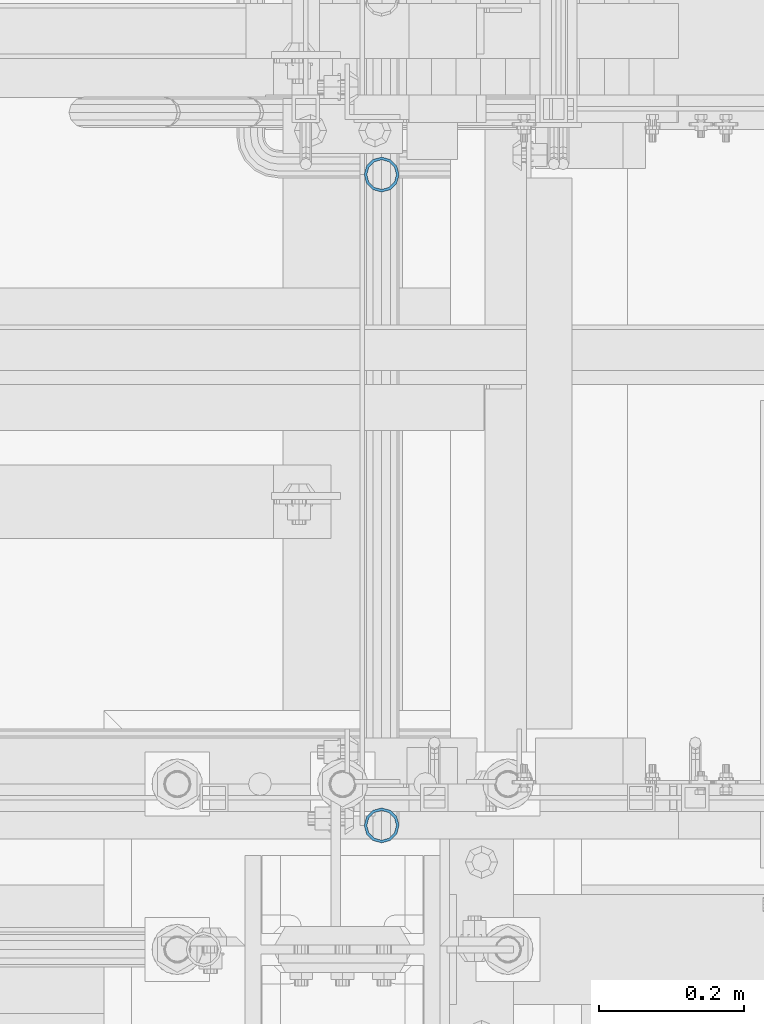
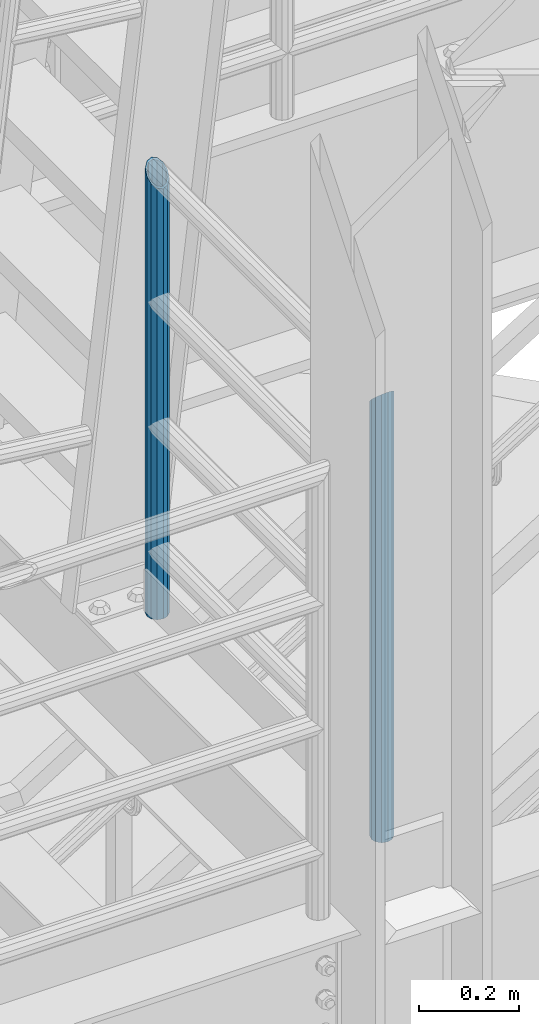
# One storey, part 572 of 1876: 2 columns, 1 element without a shape of its own.
"""IFC2X3 building model written with IfcOpenShell, lengths in millimetres."""

from ifc_helpers import new_model, si_unit, frame, origin_with_axes, place, context, subcontext, project, spatial, faceted_brep, material, type_object, element, aggregate, save


model = new_model("IFC2X3")

# Units and contexts
model_context = context("Model", 3, precision=1e-05, world=origin_with_axes())
body_context = subcontext(model_context, "Body", "Model", "MODEL_VIEW")
ifc_project = project(units=[si_unit("LENGTHUNIT", "METRE", prefix="MILLI"), si_unit("AREAUNIT", "SQUARE_METRE"), si_unit("VOLUMEUNIT", "CUBIC_METRE"), si_unit("MASSUNIT", "GRAM", prefix="KILO"), si_unit("TIMEUNIT", "SECOND"), si_unit("PLANEANGLEUNIT", "RADIAN"), si_unit("SOLIDANGLEUNIT", "STERADIAN"), si_unit("THERMODYNAMICTEMPERATUREUNIT", "DEGREE_CELSIUS"), si_unit("LUMINOUSINTENSITYUNIT", "LUMEN")], contexts=[model_context])

# Site, building, storey
site_placement = place(None, origin_with_axes())
site = spatial("IfcSite", under=ifc_project, at=site_placement, CompositionType="ELEMENT")
building_placement = place(site_placement, origin_with_axes())
building = spatial("IfcBuilding", under=site, at=building_placement, Name="Undefined", CompositionType="ELEMENT")
storey_placement = place(building_placement, origin_with_axes())
storey = spatial("IfcBuildingStorey", under=building, at=storey_placement, Name="Undefined", CompositionType="ELEMENT", Elevation=0.0)

# Assembly, columns
assembly_placement = place(storey_placement, origin_with_axes())
assembly = element("IfcElementAssembly", 1, at=assembly_placement, inside=storey, Name="RAIL", AssemblyPlace="NOTDEFINED", PredefinedType="RIGID_FRAME")
ifc_material = material()
column_type = type_object("IfcColumnType", Name="PIPE1-1/2SCH40", PredefinedType="NOTDEFINED")
column_1_placement = place(assembly_placement, frame((1781.17499999997, -6040.755, 17983.2), z_axis=(0.0, 1.0, 0.0), x_axis=(0.0, 0.0, 1.0)))
column_1 = element("IfcColumn", 2, at=column_1_placement, type_object=column_type, material=ifc_material, Name="POST", ObjectType="PIPE1-1/2SCH40", context=body_context, shape_type="Brep", body=[
    faceted_brep([(0.0, -20.4469999999999, 0.0), (0.0, -17.7076214311803, 10.2235000000001), (1086.54849999999, -17.7076214311801, 10.2235000000001), (1076.325, -20.4469999999999, 0.0), (0.0, -10.2235000000001, 17.7076214311801), (1094.03262143117, -10.2235000000001, 17.7076214311801), (-1.45519152283669e-11, 0.0, 20.4470000000001), (1096.77199999999, 0.0, 20.4470000000001), (0.0, 10.2235000000001, 17.7076214311801), (1094.03262143117, 10.2235000000001, 17.7076214311801), (0.0, 17.7076214311803, 10.2235000000001), (1086.54849999999, 17.7076214311801, 10.2235000000001), (0.0, 20.4469999999999, 0.0), (1076.325, 20.4469999999999, 0.0), (0.0, 17.7076214311803, -10.2235000000001), (1066.10149999999, 17.7076214311801, -10.2235000000001), (0.0, 10.2235000000001, -17.7076214311801), (1058.61737856881, 10.2235000000001, -17.7076214311801), (-1.45519152283669e-11, 0.0, -20.4470000000001), (1055.87799999999, 0.0, -20.4470000000001), (0.0, -10.2235000000001, -17.7076214311801), (1058.61737856881, -10.2235000000001, -17.7076214311801), (0.0, -17.7076214311803, -10.2235000000001), (1066.10149999999, -17.7076214311801, -10.2235000000001), (0.0, -24.1299999999992, 0.0), (0.0, -20.8971929933184, -12.0649999999996), (1064.25999999999, -20.8971929933186, -12.0649999999996), (1076.325, -24.1300000000001, 0.0), (0.0, -12.0650000000001, -20.8971929933186), (1055.42780700667, -12.0649999999996, -20.8971929933186), (-1.45519152283669e-11, 0.0, -24.130000000001), (1052.19499999999, 0.0, -24.1300000000001), (0.0, 12.0650000000001, -20.8971929933186), (1055.42780700667, 12.0649999999996, -20.8971929933186), (0.0, 20.8971929933184, -12.0649999999996), (1064.25999999999, 20.8971929933186, -12.0649999999996), (0.0, 24.1299999999992, 0.0), (1076.325, 24.1300000000001, 0.0), (0.0, 20.8971929933184, 12.0649999999996), (1088.38999999999, 20.8971929933186, 12.0649999999996), (0.0, 12.0650000000001, 20.8971929933186), (1097.22219299331, 12.0649999999996, 20.8971929933186), (-1.45519152283669e-11, 0.0, 24.130000000001), (1100.45499999999, 0.0, 24.1300000000001), (0.0, -12.0650000000001, 20.8971929933186), (1097.22219299331, -12.0649999999996, 20.8971929933186), (0.0, -20.8971929933184, 12.0649999999996), (1088.38999999999, -20.8971929933186, 12.0649999999996)], [[[0, 1, 2, 3]], [[1, 4, 5, 2]], [[4, 6, 7, 5]], [[6, 8, 9, 7]], [[8, 10, 11, 9]], [[10, 12, 13, 11]], [[12, 14, 15, 13]], [[14, 16, 17, 15]], [[16, 18, 19, 17]], [[18, 20, 21, 19]], [[20, 22, 23, 21]], [[22, 0, 3, 23]], [[24, 25, 26, 27]], [[25, 28, 29, 26]], [[28, 30, 31, 29]], [[30, 32, 33, 31]], [[32, 34, 35, 33]], [[34, 36, 37, 35]], [[36, 38, 39, 37]], [[38, 40, 41, 39]], [[40, 42, 43, 41]], [[42, 44, 45, 43]], [[44, 46, 47, 45]], [[46, 24, 27, 47]], [[29, 31, 33, 35, 37, 39, 41, 43, 45, 47, 27, 26], [5, 7, 9, 11, 13, 15, 17, 19, 21, 23, 3, 2]], [[46, 44, 42, 40, 38, 36, 34, 32, 30, 28, 25, 24], [22, 20, 18, 16, 14, 12, 10, 8, 6, 4, 1, 0]]]),
])
column_2_placement = place(assembly_placement, frame((1781.175, -6940.55, 17983.2), z_axis=(0.0, 1.0, 0.0), x_axis=(0.0, 0.0, 1.0)))
column_2 = element("IfcColumn", 3, at=column_2_placement, type_object=column_type, material=ifc_material, Name="POST", ObjectType="PIPE1-1/2SCH40", context=body_context, shape_type="Brep", body=[
    faceted_brep([(0.0, -20.4469999999999, 0.0), (0.0, -17.7076214311803, 10.2235000000001), (1066.1015, -17.7076214311803, 10.2235000000001), (1076.325, -20.4469999999999, 0.0), (0.0, -10.2235000000001, 17.7076214311801), (1058.61737856882, -10.2235000000001, 17.7076214311801), (-1.45519152283669e-11, 0.0, 20.4470000000001), (1055.878, 0.0, 20.4470000000001), (0.0, 10.2235000000001, 17.7076214311801), (1058.61737856882, 10.2235000000001, 17.7076214311801), (0.0, 17.7076214311803, 10.2235000000001), (1066.1015, 17.7076214311803, 10.2235000000001), (0.0, 20.4469999999999, 0.0), (1076.325, 20.4469999999999, 0.0), (0.0, 17.7076214311803, -10.2235000000001), (1086.5485, 17.7076214311803, -10.2235000000001), (0.0, 10.2235000000001, -17.7076214311801), (1094.03262143118, 10.2235000000001, -17.7076214311801), (-1.45519152283669e-11, 0.0, -20.4470000000001), (1096.772, 0.0, -20.4470000000001), (0.0, -10.2235000000001, -17.7076214311801), (1094.03262143118, -10.2235000000001, -17.7076214311801), (0.0, -17.7076214311803, -10.2235000000001), (1086.5485, -17.7076214311803, -10.2235000000001), (0.0, -24.1299999999992, 0.0), (0.0, -20.8971929933184, -12.0649999999996), (1088.39, -20.8971929933184, -12.0649999999996), (1076.325, -24.1300000000001, 0.0), (0.0, -12.0650000000001, -20.8971929933186), (1097.22219299332, -12.0650000000001, -20.8971929933186), (-1.45519152283669e-11, 0.0, -24.130000000001), (1100.455, 0.0, -24.1300000000001), (0.0, 12.0650000000001, -20.8971929933186), (1097.22219299332, 12.0650000000001, -20.8971929933186), (0.0, 20.8971929933184, -12.0649999999996), (1088.39, 20.8971929933184, -12.0649999999996), (0.0, 24.1299999999992, 0.0), (1076.325, 24.1300000000001, 0.0), (0.0, 20.8971929933184, 12.0649999999996), (1064.26, 20.8971929933184, 12.0649999999996), (0.0, 12.0650000000001, 20.8971929933186), (1055.42780700668, 12.0650000000001, 20.8971929933186), (-1.45519152283669e-11, 0.0, 24.130000000001), (1052.195, 0.0, 24.1300000000001), (0.0, -12.0650000000001, 20.8971929933186), (1055.42780700668, -12.0650000000001, 20.8971929933186), (0.0, -20.8971929933184, 12.0649999999996), (1064.26, -20.8971929933184, 12.0649999999996)], [[[0, 1, 2, 3]], [[1, 4, 5, 2]], [[4, 6, 7, 5]], [[6, 8, 9, 7]], [[8, 10, 11, 9]], [[10, 12, 13, 11]], [[12, 14, 15, 13]], [[14, 16, 17, 15]], [[16, 18, 19, 17]], [[18, 20, 21, 19]], [[20, 22, 23, 21]], [[22, 0, 3, 23]], [[24, 25, 26, 27]], [[25, 28, 29, 26]], [[28, 30, 31, 29]], [[30, 32, 33, 31]], [[32, 34, 35, 33]], [[34, 36, 37, 35]], [[36, 38, 39, 37]], [[38, 40, 41, 39]], [[40, 42, 43, 41]], [[42, 44, 45, 43]], [[44, 46, 47, 45]], [[46, 24, 27, 47]], [[29, 31, 33, 35, 37, 39, 41, 43, 45, 47, 27, 26], [5, 7, 9, 11, 13, 15, 17, 19, 21, 23, 3, 2]], [[46, 44, 42, 40, 38, 36, 34, 32, 30, 28, 25, 24], [22, 20, 18, 16, 14, 12, 10, 8, 6, 4, 1, 0]]]),
])
aggregate(assembly, [column_1, column_2])

save(model, "model.ifc")
